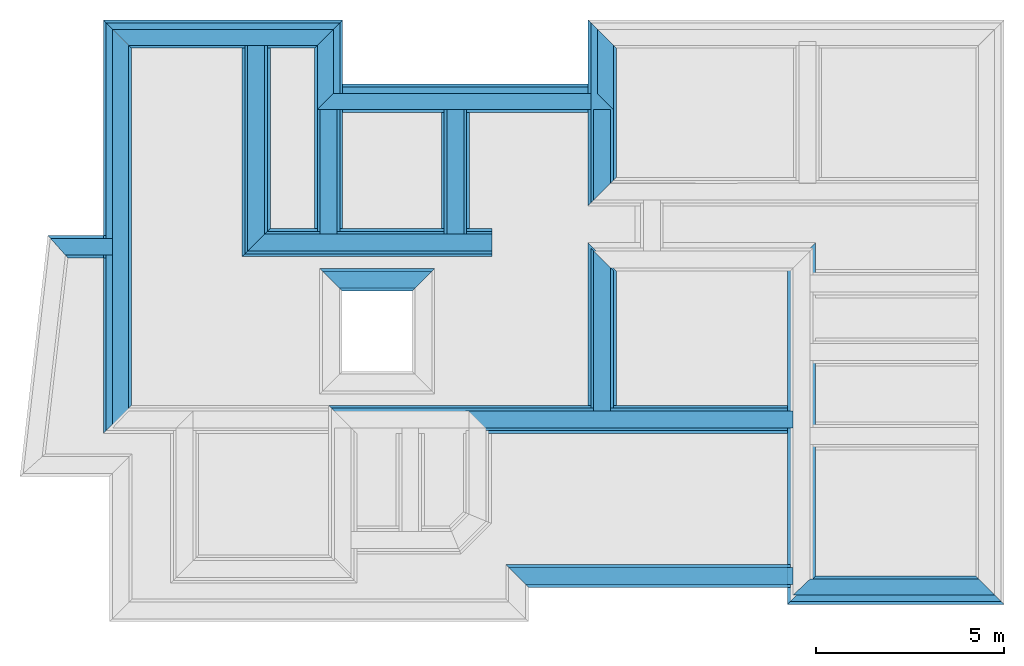
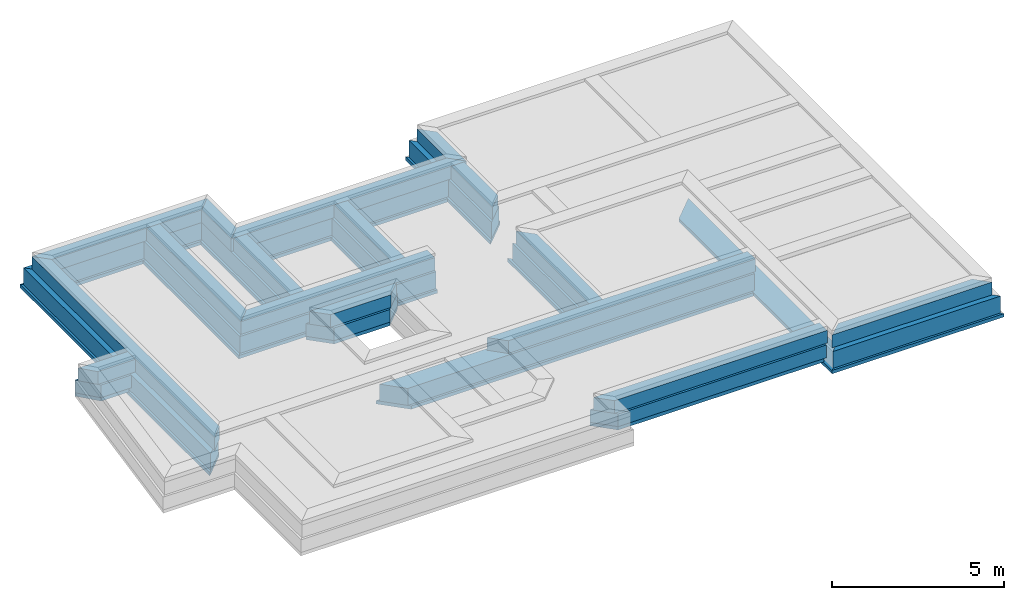
# One storey, part 3 of 6: 45 walls.
"""IFC4X3_ADD2 building model written with IfcOpenShell, lengths in metres."""

from ifc_helpers import new_model, entity, si_unit, converted_unit, frame, origin_with_axes, origin_2d_with_axis, place, context, subcontext, project, spatial, line, indexed_curve, outline, extrude, material, layer, layer_set, layer_usage, type_object, element, save


model = new_model("IFC4X3_ADD2")

# Units and contexts
model_context = context("Model", 3, precision=1e-05, world=origin_with_axes())
plan_context = context("Plan", 2, precision=1e-05, world=origin_2d_with_axis())
body_context = subcontext(model_context, "Body", "Model", "MODEL_VIEW")
ifc_project = project(units=[si_unit("VOLUMEUNIT", "CUBIC_METRE"), si_unit("LENGTHUNIT", "METRE"), converted_unit("PLANEANGLEUNIT", "degree", entity("IfcReal", 0.0174532925199433), si_unit("PLANEANGLEUNIT", "RADIAN"), dimensions=[0, 0, 0, 0, 0, 0, 0]), si_unit("AREAUNIT", "SQUARE_METRE")], contexts=[model_context, plan_context])

# Site, building, storey
site_placement = place(None, origin_with_axes())
site = spatial("IfcSite", under=ifc_project, at=site_placement)
building_placement = place(site_placement, origin_with_axes())
building = spatial("IfcBuilding", under=site, at=building_placement, Name="Building")
storey_placement = place(building_placement, frame((0.0, 0.0, -0.870000004768372), z_axis=(0.0, 0.0, 1.0), x_axis=(1.0, 0.0, 0.0)))
storey = spatial("IfcBuildingStorey", under=building, at=storey_placement, Name="Footing")

# Walls
ifc_material_1 = material(Name="Stone", Category="Structure")
ifc_layer_1 = layer(ifc_material_1, 0.449999988079071)
ifc_layer_set_1 = layer_set([ifc_layer_1])
ifc_layer_usage_1 = layer_usage(ifc_layer_set_1, "AXIS2", "POSITIVE", 0.0)
wall_type_1 = type_object("IfcWallType", Name="RRB Basement", PredefinedType="SHEAR", material=ifc_layer_set_1)
wall_1_placement = place(storey_placement, frame((11.1843014234303, 20.5243861418143, 0.719999998807908), z_axis=(0.0, 0.0, 1.0), x_axis=(3.13916473260163e-07, 0.999999999999951, 0.0)))
element("IfcWall", 1, at=wall_1_placement, inside=storey, type_object=wall_type_1, material=ifc_layer_usage_1, Name="Wall", context=body_context, shape_type="SweptSolid", body=[
    extrude(outline(indexed_curve([(0.449999988079093, 0.0), (0.450000131326058, 0.449999988079071), (3.76552144418195, 0.449999988079071), (3.76552141414186, 0.0)], segments=[line(1, 2, 3, 4, 1)])), origin_with_axes(), (0.0, 0.0, 1.0), 0.449999988079071),
])
ifc_layer_usage_2 = layer_usage(ifc_layer_set_1, "AXIS2", "POSITIVE", 0.0)
wall_2_placement = place(storey_placement, frame((15.0466774778525, 15.8160228729249, 0.719999998807908), z_axis=(0.0, 0.0, 1.0), x_axis=(0.999999999999822, -5.960464477538e-07, 0.0)))
element("IfcWall", 2, at=wall_2_placement, inside=storey, type_object=wall_type_1, material=ifc_layer_usage_2, Name="Wall", context=body_context, shape_type="SweptSolid", body=[
    extrude(outline(indexed_curve([(0.0, 0.0), (-0.450000103371296, 0.449999988079071), (8.2783390779459, 0.449999988079071), (8.27833917616148, 0.0)], segments=[line(1, 2, 3, 4, 1)])), origin_with_axes(), (0.0, 0.0, 1.0), 0.449999988079071),
])
ifc_layer_usage_3 = layer_usage(ifc_layer_set_1, "AXIS2", "POSITIVE", 0.0)
wall_3_placement = place(storey_placement, frame((14.5602179044483, 20.5243840074145, 0.719999998807908), z_axis=(0.0, 0.0, 1.0), x_axis=(3.13916473260163e-07, 0.999999999999951, 0.0)))
element("IfcWall", 3, at=wall_3_placement, inside=storey, type_object=wall_type_1, material=ifc_layer_usage_3, Name="Wall", context=body_context, shape_type="SweptSolid", body=[
    extrude(outline(indexed_curve([(0.449999988079094, 0.0), (0.450000131326058, 0.449999988079071), (3.76552229320457, 0.449999988079071), (3.76552226325902, 0.0)], segments=[line(1, 2, 3, 4, 1)])), origin_with_axes(), (0.0, 0.0, 1.0), 0.449999988079071),
])
ifc_layer_usage_4 = layer_usage(ifc_layer_set_1, "AXIS2", "POSITIVE", 0.0)
wall_4_placement = place(storey_placement, frame((9.25813584268061, 20.5243873596191, 0.719999998807908), z_axis=(0.0, 0.0, 1.0), x_axis=(3.13916473260163e-07, 0.999999999999951, 0.0)))
element("IfcWall", 4, at=wall_4_placement, inside=storey, type_object=wall_type_1, material=ifc_layer_usage_4, Name="Wall", context=body_context, shape_type="SweptSolid", body=[
    extrude(outline(indexed_curve([(0.449999988079093, 0.0), (1.43246964352757e-07, 0.449999988079071), (5.57351498957041, 0.449999988079071), (5.57351496081623, 0.0)], segments=[line(1, 2, 3, 4, 1)])), origin_with_axes(), (0.0, 0.0, 1.0), 0.449999988079071),
])
ifc_layer_usage_5 = layer_usage(ifc_layer_set_1, "AXIS2", "POSITIVE", 0.0)
wall_5_placement = place(storey_placement, frame((9.25813584427108, 20.5243873596191, 0.719999998807908), z_axis=(0.0, 0.0, 1.0), x_axis=(0.999999999999822, -5.960464477538e-07, 0.0)))
element("IfcWall", 5, at=wall_5_placement, inside=storey, type_object=wall_type_1, material=ifc_layer_usage_5, Name="Wall", context=body_context, shape_type="SweptSolid", body=[
    extrude(outline(indexed_curve([(-0.449999988079087, 0.0), (-1.22067763074548e-07, 0.449999988079071), (6.05208381845608, 0.449999988079071), (6.05208381845608, 0.0)], segments=[line(1, 2, 3, 4, 1)])), origin_with_axes(), (0.0, 0.0, 1.0), 0.449999988079071),
])
ifc_layer_usage_6 = layer_usage(ifc_layer_set_1, "AXIS2", "POSITIVE", 0.0)
wall_6_placement = place(storey_placement, frame((18.466682434082, 21.8778953552246, 0.719999998807908), z_axis=(0.0, 0.0, 1.0), x_axis=(3.13916473260163e-07, 0.999999999999951, 0.0)))
element("IfcWall", 6, at=wall_6_placement, inside=storey, type_object=wall_type_1, material=ifc_layer_usage_6, Name="Wall", context=body_context, shape_type="SweptSolid", body=[
    extrude(outline(indexed_curve([(0.44999998807909, 0.0), (1.2982553602409e-07, 0.449999988079071), (2.41201430465592, 0.449999988079071), (2.41201460685087, 0.0)], segments=[line(1, 2, 3, 4, 1)])), origin_with_axes(), (0.0, 0.0, 1.0), 0.449999988079071),
])
ifc_layer_usage_7 = layer_usage(ifc_layer_set_1, "AXIS2", "POSITIVE", 0.0)
wall_7_placement = place(storey_placement, frame((18.466680573821, 15.8160208088996, 0.719999998807908), z_axis=(0.0, 0.0, 1.0), x_axis=(3.13916473260163e-07, 0.999999999999951, 0.0)))
element("IfcWall", 7, at=wall_7_placement, inside=storey, type_object=wall_type_1, material=ifc_layer_usage_7, Name="Wall", context=body_context, shape_type="SweptSolid", body=[
    extrude(outline(indexed_curve([(0.44999998807909, 0.0), (0.450000118398703, 0.449999988079071), (4.70687373541192, 0.449999988079071), (4.256873653544, 0.0)], segments=[line(1, 2, 3, 4, 1)])), origin_with_axes(), (0.0, 0.0, 1.0), 0.449999988079071),
])
ifc_layer_usage_8 = layer_usage(ifc_layer_set_1, "AXIS2", "POSITIVE", 0.0)
wall_8_placement = place(storey_placement, frame((16.2040448841746, 11.6493488347191, 0.719999998807908), z_axis=(0.0, 0.0, 1.0), x_axis=(0.999999999999822, -5.960464477538e-07, 0.0)))
element("IfcWall", 8, at=wall_8_placement, inside=storey, type_object=wall_type_1, material=ifc_layer_usage_8, Name="Wall", context=body_context, shape_type="SweptSolid", body=[
    extrude(outline(indexed_curve([(0.0, 0.0), (-0.449999989155844, 0.449999988079071), (7.12097009124434, 0.449999988079071), (7.12097018937736, 0.0)], segments=[line(1, 2, 3, 4, 1)])), origin_with_axes(), (0.0, 0.0, 1.0), 0.449999988079071),
])
ifc_layer_usage_9 = layer_usage(ifc_layer_set_1, "AXIS2", "POSITIVE", 0.0)
wall_9_placement = place(storey_placement, frame((5.6390405123403, 20.8634834375414, 0.719999998807908), z_axis=(0.0, 0.0, 1.0), x_axis=(-0.999999999999803, 6.27832946520233e-07, 0.0)))
element("IfcWall", 9, at=wall_9_placement, inside=storey, type_object=wall_type_1, material=ifc_layer_usage_9, Name="Wall", context=body_context, shape_type="SweptSolid", body=[
    extrude(outline(indexed_curve([(0.425000000745078, 0.0), (0.424999862371063, 0.449999988079071), (1.68367306365502, 0.449999988079071), (2.08469309225921, 0.0)], segments=[line(1, 2, 3, 4, 1)])), origin_with_axes(), (0.0, 0.0, 1.0), 0.449999988079071),
])
ifc_layer_usage_10 = layer_usage(ifc_layer_set_1, "AXIS2", "POSITIVE", 0.0)
wall_10_placement = place(storey_placement, frame((13.7089599315482, 19.9843861870825, 0.719999983906746), z_axis=(0.0, 0.0, 1.0), x_axis=(-0.999999999999803, 6.27832946520233e-07, 0.0)))
element("IfcWall", 10, at=wall_10_placement, inside=storey, type_object=wall_type_1, material=ifc_layer_usage_10, Name="Wall", context=body_context, shape_type="SweptSolid", body=[
    extrude(outline(indexed_curve([(0.0, 0.0), (0.450000016741684, 0.449999988079071), (2.46327593529409, 0.449999988079071), (2.91327589750235, 0.0)], segments=[line(1, 2, 3, 4, 1)])), origin_with_axes(), (0.0, 0.0, 1.0), 0.449999988079071),
])
ifc_material_2 = material(Name="Plaster", Category="Finishes")
ifc_layer_2 = layer(ifc_material_2, 0.00999999977648258)
ifc_layer_3 = layer(ifc_material_1, 0.405000001192093)
ifc_layer_4 = layer(ifc_material_2, 0.00999999977648258)
ifc_layer_set_2 = layer_set([ifc_layer_2, ifc_layer_3, ifc_layer_4])
ifc_layer_usage_11 = layer_usage(ifc_layer_set_2, "AXIS2", "POSITIVE", 0.0)
wall_type_2 = type_object("IfcWallType", Name="RRB Basement Flush 425", PredefinedType="SHEAR", material=ifc_layer_set_2)
wall_11_placement = place(storey_placement, frame((11.0843045825103, 26.4228992462159, 0.719999998807908), z_axis=(0.0, 0.0, 1.0), x_axis=(-0.999999999999924, 3.89414367418765e-07, 0.0)))
element("IfcWall", 11, at=wall_11_placement, inside=storey, type_object=wall_type_2, material=ifc_layer_usage_11, Name="Wall", context=body_context, shape_type="SweptSolid", body=[
    extrude(outline(indexed_curve([(0.0, 0.0), (0.424999984673434, 0.425000000745058), (5.44526225995521, 0.425000000745058), (5.87026229003865, 0.0)], segments=[line(1, 2, 3, 4, 1)])), origin_with_axes(), (0.0, 0.0, 1.0), 0.449999988079071),
])
ifc_layer_usage_12 = layer_usage(ifc_layer_set_2, "AXIS2", "POSITIVE", 0.0)
wall_12_placement = place(storey_placement, frame((18.5416841319606, 24.7149047559503, 0.719999998807908), z_axis=(0.0, 0.0, 1.0), x_axis=(-0.999999999999924, 3.89414367418765e-07, 0.0)))
element("IfcWall", 12, at=wall_12_placement, inside=storey, type_object=wall_type_2, material=ifc_layer_usage_12, Name="Wall", context=body_context, shape_type="SweptSolid", body=[
    extrude(outline(indexed_curve([(0.425000000745095, 0.0), (-5.01506110114182e-07, 0.425000000745058), (7.88238015246545, 0.425000000745058), (7.45738016349185, 0.0)], segments=[line(1, 2, 3, 4, 1)])), origin_with_axes(), (0.0, 0.0, 1.0), 0.449999988079071),
])
ifc_layer_usage_13 = layer_usage(ifc_layer_set_2, "AXIS2", "POSITIVE", 0.0)
wall_13_placement = place(storey_placement, frame((5.63903903961169, 16.2660213158936, 0.719999998807908), z_axis=(0.0, 0.0, 1.0), x_axis=(3.13916473260163e-07, 0.999999999999951, 0.0)))
element("IfcWall", 13, at=wall_13_placement, inside=storey, type_object=wall_type_2, material=ifc_layer_usage_13, Name="Wall", context=body_context, shape_type="SweptSolid", body=[
    extrude(outline(indexed_curve([(0.0, 0.0), (-0.450000223773091, 0.425000000745058), (10.156880012591, 0.425000000745058), (9.73187998484762, 0.0)], segments=[line(1, 2, 3, 4, 1)])), origin_with_axes(), (0.0, 0.0, 1.0), 0.449999988079071),
])
ifc_layer_usage_14 = layer_usage(ifc_layer_set_2, "AXIS2", "POSITIVE", 0.0)
wall_14_placement = place(storey_placement, frame((23.7750149621858, 11.3693475723266, 0.719999998807908), z_axis=(0.0, 0.0, 1.0), x_axis=(0.999999999999822, -5.960464477538e-07, 0.0)))
element("IfcWall", 14, at=wall_14_placement, inside=storey, type_object=wall_type_2, material=ifc_layer_usage_14, Name="Wall", context=body_context, shape_type="SweptSolid", body=[
    extrude(outline(indexed_curve([(-0.449999988079081, 0.0), (-9.26811892745667e-08, 0.425000000745058), (4.48665335278053, 0.425000000745058), (4.91165347159026, 0.0)], segments=[line(1, 2, 3, 4, 1)])), origin_with_axes(), (0.0, 0.0, 1.0), 0.449999988079071),
])
ifc_layer_usage_15 = layer_usage(ifc_layer_set_2, "AXIS2", "POSITIVE", 0.0)
wall_15_placement = place(storey_placement, frame((11.0843039684693, 24.7149075947677, 0.719999998807908), z_axis=(0.0, 0.0, 1.0), x_axis=(3.13916473260163e-07, 0.999999999999951, 0.0)))
element("IfcWall", 15, at=wall_15_placement, inside=storey, type_object=wall_type_2, material=ifc_layer_usage_15, Name="Wall", context=body_context, shape_type="SweptSolid", body=[
    extrude(outline(indexed_curve([(0.0, 0.0), (-0.424999972373865, 0.425000000745058), (1.2829916777015, 0.425000000745058), (1.70799165144828, 0.0)], segments=[line(1, 2, 3, 4, 1)])), origin_with_axes(), (0.0, 0.0, 1.0), 0.449999988079071),
])
ifc_layer_usage_16 = layer_usage(ifc_layer_set_2, "AXIS2", "POSITIVE", 0.0)
wall_16_placement = place(storey_placement, frame((18.5416841319606, 24.7149047566126, 0.719999998807908), z_axis=(0.0, 0.0, 1.0), x_axis=(3.13916473260163e-07, 0.999999999999951, 0.0)))
element("IfcWall", 16, at=wall_16_placement, inside=storey, type_object=wall_type_2, material=ifc_layer_usage_16, Name="Wall", context=body_context, shape_type="SweptSolid", body=[
    extrude(outline(indexed_curve([(-0.425000000745059, 0.0), (2.83334474771024e-08, 0.425000000745058), (1.70799653596367, 0.425000000745058), (1.28299650586313, 0.0)], segments=[line(1, 2, 3, 4, 1)])), origin_with_axes(), (0.0, 0.0, 1.0), 0.449999988079071),
])
ifc_material_3 = material(Name="Wall")
ifc_layer_5 = layer(ifc_material_3, 0.600000023841858, Name="concrete")
ifc_layer_set_3 = layer_set([ifc_layer_5], Name="concrete")
ifc_layer_usage_17 = layer_usage(ifc_layer_set_3, "AXIS2", "POSITIVE", 0.0)
wall_type_3 = type_object("IfcWallType", Name="RRB Foundation", PredefinedType="SHEAR", material=ifc_layer_set_3)
wall_17_placement = place(storey_placement, frame((18.5416813132168, 21.802896544815, 0.120000004768372), z_axis=(0.0, 0.0, 1.0), x_axis=(3.13916473260163e-07, 0.999999999999951, 0.0)))
element("IfcWall", 17, at=wall_17_placement, inside=storey, type_object=wall_type_3, material=ifc_layer_usage_17, Name="Wall", context=body_context, shape_type="SweptSolid", body=[
    extrude(outline(indexed_curve([(0.600000023841883, 0.0), (1.7306831381862e-07, 0.600000023841858), (4.79500596321352, 0.600000023841858), (4.19500589786325, 0.0)], segments=[line(1, 2, 3, 4, 1)])), origin_with_axes(), (0.0, 0.0, 1.0), 0.600000023841858),
])
ifc_layer_usage_18 = layer_usage(ifc_layer_set_3, "AXIS2", "POSITIVE", 0.0)
wall_18_placement = place(storey_placement, frame((9.33313562840178, 20.4493865966797, 0.120000004768372), z_axis=(0.0, 0.0, 1.0), x_axis=(3.13916473260163e-07, 0.999999999999951, 0.0)))
element("IfcWall", 18, at=wall_18_placement, inside=storey, type_object=wall_type_3, material=ifc_layer_usage_18, Name="Wall", context=body_context, shape_type="SweptSolid", body=[
    extrude(outline(indexed_curve([(0.600000023841888, 0.0), (1.91268479846074e-07, 0.600000023841858), (5.54851456538258, 0.600000023841858), (5.54851452704368, 0.0)], segments=[line(1, 2, 3, 4, 1)])), origin_with_axes(), (0.0, 0.0, 1.0), 0.600000023841858),
])
ifc_layer_usage_19 = layer_usage(ifc_layer_set_3, "AXIS2", "POSITIVE", 0.0)
wall_19_placement = place(storey_placement, frame((18.5416823246089, 24.8899059587721, 0.120000004768372), z_axis=(0.0, 0.0, 1.0), x_axis=(-0.999999999999924, 3.89414367418765e-07, 0.0)))
element("IfcWall", 19, at=wall_19_placement, inside=storey, type_object=wall_type_3, material=ifc_layer_usage_19, Name="Wall", context=body_context, shape_type="SweptSolid", body=[
    extrude(outline(indexed_curve([(0.600000023841859, 0.0), (0.599999986700795, 0.600000023841858), (7.2823786814523, 0.600000023841858), (7.28237872038916, 0.0)], segments=[line(1, 2, 3, 4, 1)])), origin_with_axes(), (0.0, 0.0, 1.0), 0.600000023841858),
])
ifc_layer_usage_20 = layer_usage(ifc_layer_set_3, "AXIS2", "POSITIVE", 0.0)
wall_20_placement = place(storey_placement, frame((18.5416794058681, 15.7410208639421, 0.120000004768372), z_axis=(0.0, 0.0, 1.0), x_axis=(3.13916473260163e-07, 0.999999999999951, 0.0)))
element("IfcWall", 20, at=wall_20_placement, inside=storey, type_object=wall_type_3, material=ifc_layer_usage_20, Name="Wall", context=body_context, shape_type="SweptSolid", body=[
    extrude(outline(indexed_curve([(0.600000023841883, 0.0), (0.600000196322957, 0.600000023841858), (4.85687366928037, 0.600000023841858), (4.25687346879169, 0.0)], segments=[line(1, 2, 3, 4, 1)])), origin_with_axes(), (0.0, 0.0, 1.0), 0.600000023841858),
])
ifc_layer_usage_21 = layer_usage(ifc_layer_set_3, "AXIS2", "POSITIVE", 0.0)
wall_21_placement = place(storey_placement, frame((11.2593041573632, 26.597900419831, 0.120000004768372), z_axis=(0.0, 0.0, 1.0), x_axis=(-0.999999999999924, 3.89414367418765e-07, 0.0)))
element("IfcWall", 21, at=wall_21_placement, inside=storey, type_object=wall_type_3, material=ifc_layer_usage_21, Name="Wall", context=body_context, shape_type="SweptSolid", body=[
    extrude(outline(indexed_curve([(0.0, 0.0), (0.599999984828332, 0.600000023841858), (5.62026181561733, 0.600000023841858), (6.22026188091619, 0.0)], segments=[line(1, 2, 3, 4, 1)])), origin_with_axes(), (0.0, 0.0, 1.0), 0.600000023841858),
])
ifc_layer_usage_22 = layer_usage(ifc_layer_set_3, "AXIS2", "POSITIVE", 0.0)
wall_22_placement = place(storey_placement, frame((11.2593021628258, 20.4493853779994, 0.120000004768372), z_axis=(0.0, 0.0, 1.0), x_axis=(3.13916473260163e-07, 0.999999999999951, 0.0)))
element("IfcWall", 22, at=wall_22_placement, inside=storey, type_object=wall_type_3, material=ifc_layer_usage_22, Name="Wall", context=body_context, shape_type="SweptSolid", body=[
    extrude(outline(indexed_curve([(0.600000023841888, 0.0), (0.600000215110368, 0.600000023841858), (5.54851505632895, 0.600000023841858), (6.1485150418319, 0.0)], segments=[line(1, 2, 3, 4, 1)])), origin_with_axes(), (0.0, 0.0, 1.0), 0.600000023841858),
])
ifc_layer_usage_23 = layer_usage(ifc_layer_set_3, "AXIS2", "POSITIVE", 0.0)
wall_23_placement = place(storey_placement, frame((11.6379987314599, 15.7410250157116, 0.120000004768372), z_axis=(0.0, 0.0, 1.0), x_axis=(0.999999999999822, -5.960464477538e-07, 0.0)))
element("IfcWall", 23, at=wall_23_placement, inside=storey, type_object=wall_type_3, material=ifc_layer_usage_23, Name="Wall", context=body_context, shape_type="SweptSolid", body=[
    extrude(outline(indexed_curve([(0.0, 0.0), (-0.600000181284445, 0.600000023841858), (11.6120162987777, 0.600000023841858), (11.6120164636125, 0.0)], segments=[line(1, 2, 3, 4, 1)])), origin_with_axes(), (0.0, 0.0, 1.0), 0.600000023841858),
])
ifc_layer_usage_24 = layer_usage(ifc_layer_set_3, "AXIS2", "POSITIVE", 0.0)
wall_24_placement = place(storey_placement, frame((9.33313562918742, 20.4493865966797, 0.120000004768372), z_axis=(0.0, 0.0, 1.0), x_axis=(0.999999999999822, -5.960464477538e-07, 0.0)))
element("IfcWall", 24, at=wall_24_placement, inside=storey, type_object=wall_type_3, material=ifc_layer_usage_24, Name="Wall", context=body_context, shape_type="SweptSolid", body=[
    extrude(outline(indexed_curve([(-0.60000002384188, 0.0), (-1.62916114084486e-07, 0.600000023841858), (5.97708403273492, 0.600000023841858), (5.97708403273492, 0.0)], segments=[line(1, 2, 3, 4, 1)])), origin_with_axes(), (0.0, 0.0, 1.0), 0.600000023841858),
])
ifc_layer_usage_25 = layer_usage(ifc_layer_set_3, "AXIS2", "POSITIVE", 0.0)
wall_25_placement = place(storey_placement, frame((5.63903901606797, 16.3410209768514, 0.120000004768372), z_axis=(0.0, 0.0, 1.0), x_axis=(3.13916473260163e-07, 0.999999999999951, 0.0)))
element("IfcWall", 25, at=wall_25_placement, inside=storey, type_object=wall_type_3, material=ifc_layer_usage_25, Name="Wall", context=body_context, shape_type="SweptSolid", body=[
    extrude(outline(indexed_curve([(0.0, 0.0), (-0.5999999850636, 0.600000023841858), (10.2568816047363, 0.600000023841858), (9.6568815425555, 0.0)], segments=[line(1, 2, 3, 4, 1)])), origin_with_axes(), (0.0, 0.0, 1.0), 0.600000023841858),
])
ifc_layer_usage_26 = layer_usage(ifc_layer_set_3, "AXIS2", "POSITIVE", 0.0)
wall_26_placement = place(storey_placement, frame((23.8500137570046, 11.1943474262957, 0.120000004768372), z_axis=(0.0, 0.0, 1.0), x_axis=(0.999999999999822, -5.960464477538e-07, 0.0)))
element("IfcWall", 26, at=wall_26_placement, inside=storey, type_object=wall_type_3, material=ifc_layer_usage_26, Name="Wall", context=body_context, shape_type="SweptSolid", body=[
    extrude(outline(indexed_curve([(-0.600000023841881, 0.0), (-1.64834769827047e-07, 0.600000023841858), (4.41165561690321, 0.600000023841858), (5.01165580749597, 0.0)], segments=[line(1, 2, 3, 4, 1)])), origin_with_axes(), (0.0, 0.0, 1.0), 0.600000023841858),
])
ifc_layer_usage_27 = layer_usage(ifc_layer_set_3, "AXIS2", "POSITIVE", 0.0)
wall_27_placement = place(storey_placement, frame((14.6352186203005, 20.3743844314932, 0.120000004768372), z_axis=(0.0, 0.0, 1.0), x_axis=(3.13916473260163e-07, 0.999999999999951, 0.0)))
element("IfcWall", 27, at=wall_27_placement, inside=storey, type_object=wall_type_3, material=ifc_layer_usage_27, Name="Wall", context=body_context, shape_type="SweptSolid", body=[
    extrude(outline(indexed_curve([(0.600000023841888, 0.0), (0.600000215389809, 0.600000023841858), (3.91552302920591, 0.600000023841858), (3.9155229893344, 0.0)], segments=[line(1, 2, 3, 4, 1)])), origin_with_axes(), (0.0, 0.0, 1.0), 0.600000023841858),
])
ifc_layer_usage_28 = layer_usage(ifc_layer_set_3, "AXIS2", "POSITIVE", 0.0)
wall_28_placement = place(storey_placement, frame((23.8500140713483, 12.1743445783882, 0.269999980926514), z_axis=(0.0, 0.0, 1.0), x_axis=(-0.999999999999924, 3.89414367418765e-07, 0.0)))
element("IfcWall", 28, at=wall_28_placement, inside=storey, type_object=wall_type_3, material=ifc_layer_usage_28, Name="Wall", context=body_context, shape_type="SweptSolid", body=[
    extrude(outline(indexed_curve([(0.600000023841859, 0.0), (0.599999982986343, 0.600000023841858), (7.57096725031161, 0.600000023841858), (8.17096530502794, 0.0)], segments=[line(1, 2, 3, 4, 1)])), origin_with_axes(), (0.0, 0.0, 1.0), 0.449999988079071),
])
ifc_layer_usage_29 = layer_usage(ifc_layer_set_3, "AXIS2", "POSITIVE", 0.0)
wall_29_placement = place(storey_placement, frame((5.63904048850912, 20.9384838708685, 0.269999980926514), z_axis=(0.0, 0.0, 1.0), x_axis=(-0.999999999999803, 6.27832946520233e-07, 0.0)))
element("IfcWall", 29, at=wall_29_placement, inside=storey, type_object=wall_type_3, material=ifc_layer_usage_29, Name="Wall", context=body_context, shape_type="SweptSolid", body=[
    extrude(outline(indexed_curve([(0.600000023841886, 0.0), (0.599999839305639, 0.600000023841858), (1.61683742049565, 0.600000023841858), (2.15153083745776, 0.0)], segments=[line(1, 2, 3, 4, 1)])), origin_with_axes(), (0.0, 0.0, 1.0), 0.449999988079071),
])
ifc_layer_usage_30 = layer_usage(ifc_layer_set_3, "AXIS2", "POSITIVE", 0.0)
wall_30_placement = place(storey_placement, frame((10.7206868734936, 19.4593892768367, 0.269999980926514), z_axis=(0.0, 0.0, 1.0), x_axis=(0.999999999999886, -4.76837158203071e-07, 0.0)))
element("IfcWall", 30, at=wall_30_placement, inside=storey, type_object=wall_type_3, material=ifc_layer_usage_30, Name="Wall", context=body_context, shape_type="SweptSolid", body=[
    extrude(outline(indexed_curve([(0.600000023841886, 0.0), (6.56667492426315e-07, 0.600000023841858), (3.06327801910507, 0.600000023841858), (2.46327590943912, 0.0)], segments=[line(1, 2, 3, 4, 1)])), origin_with_axes(), (0.0, 0.0, 1.0), 0.449999988079071),
])
ifc_layer_6 = layer(ifc_material_3, 0.75)
ifc_layer_set_4 = layer_set([ifc_layer_6])
ifc_layer_usage_31 = layer_usage(ifc_layer_set_4, "AXIS2", "POSITIVE", 0.0)
wall_type_4 = type_object("IfcWallType", Name="PCC 120mm", PredefinedType="SHEAR", material=ifc_layer_set_4)
wall_31_placement = place(storey_placement, frame((11.3343043265543, 26.6729009988723, 0.0), z_axis=(0.0, 0.0, 1.0), x_axis=(-0.999999999999924, 3.89414367418765e-07, 0.0)))
element("IfcWall", 31, at=wall_31_placement, inside=storey, type_object=wall_type_4, material=ifc_layer_usage_31, Name="Wall", context=body_context, shape_type="SweptSolid", body=[
    extrude(outline(indexed_curve([(0.0, 0.0), (0.749999951139541, 0.75), (5.62026220810672, 0.75), (6.37026225996308, 0.0)], segments=[line(1, 2, 3, 4, 1)])), origin_with_axes(), (0.0, 0.0, 1.0), 0.119999997317791),
])
ifc_layer_usage_32 = layer_usage(ifc_layer_set_4, "AXIS2", "POSITIVE", 0.0)
wall_32_placement = place(storey_placement, frame((18.6166831257379, 24.9649062643639, 0.0), z_axis=(0.0, 0.0, 1.0), x_axis=(-0.999999999999924, 3.89414367418765e-07, 0.0)))
element("IfcWall", 32, at=wall_32_placement, inside=storey, type_object=wall_type_4, material=ifc_layer_usage_32, Name="Wall", context=body_context, shape_type="SweptSolid", body=[
    extrude(outline(indexed_curve([(0.750000000000001, 0.0), (0.749999954027897, 0.75), (7.28237930416929, 0.75), (7.28237935302975, 0.0)], segments=[line(1, 2, 3, 4, 1)])), origin_with_axes(), (0.0, 0.0, 1.0), 0.119999997317791),
])
ifc_layer_usage_33 = layer_usage(ifc_layer_set_4, "AXIS2", "POSITIVE", 0.0)
wall_33_placement = place(storey_placement, frame((5.71403878159405, 16.416021684612, 0.0), z_axis=(0.0, 0.0, 1.0), x_axis=(3.13916473260163e-07, 0.999999999999951, 0.0)))
element("IfcWall", 33, at=wall_33_placement, inside=storey, type_object=wall_type_4, material=ifc_layer_usage_33, Name="Wall", context=body_context, shape_type="SweptSolid", body=[
    extrude(outline(indexed_curve([(0.0, 0.0), (-0.74999995152718, 0.75), (10.2568814856018, 0.75), (9.50688143767821, 0.0)], segments=[line(1, 2, 3, 4, 1)])), origin_with_axes(), (0.0, 0.0, 1.0), 0.119999997317791),
])
ifc_layer_usage_34 = layer_usage(ifc_layer_set_4, "AXIS2", "POSITIVE", 0.0)
wall_34_placement = place(storey_placement, frame((11.3343022841534, 20.3743867690882, 0.0), z_axis=(0.0, 0.0, 1.0), x_axis=(3.13916473260163e-07, 0.999999999999951, 0.0)))
element("IfcWall", 34, at=wall_34_placement, inside=storey, type_object=wall_type_4, material=ifc_layer_usage_34, Name="Wall", context=body_context, shape_type="SweptSolid", body=[
    extrude(outline(indexed_curve([(0.750000000000038, 0.0), (0.750000239434929, 0.75), (5.54851427770804, 0.75), (6.29851422978442, 0.0)], segments=[line(1, 2, 3, 4, 1)])), origin_with_axes(), (0.0, 0.0, 1.0), 0.119999997317791),
])
ifc_layer_usage_35 = layer_usage(ifc_layer_set_4, "AXIS2", "POSITIVE", 0.0)
wall_35_placement = place(storey_placement, frame((9.40813504085922, 20.3743879886661, 0.0), z_axis=(0.0, 0.0, 1.0), x_axis=(3.13916473260163e-07, 0.999999999999951, 0.0)))
element("IfcWall", 35, at=wall_35_placement, inside=storey, type_object=wall_type_4, material=ifc_layer_usage_35, Name="Wall", context=body_context, shape_type="SweptSolid", body=[
    extrude(outline(indexed_curve([(0.750000000000038, 0.0), (2.39434890939613e-07, 0.75), (5.54851378586441, 0.75), (5.54851373794079, 0.0)], segments=[line(1, 2, 3, 4, 1)])), origin_with_axes(), (0.0, 0.0, 1.0), 0.119999997317791),
])
ifc_layer_usage_36 = layer_usage(ifc_layer_set_4, "AXIS2", "POSITIVE", 0.0)
wall_36_placement = place(storey_placement, frame((9.40813504085922, 20.3743879886661, 0.0), z_axis=(0.0, 0.0, 1.0), x_axis=(0.999999999999822, -5.960464477538e-07, 0.0)))
element("IfcWall", 36, at=wall_36_placement, inside=storey, type_object=wall_type_4, material=ifc_layer_usage_36, Name="Wall", context=body_context, shape_type="SweptSolid", body=[
    extrude(outline(indexed_curve([(-0.750000000000028, 0.0), (-2.03834519745982e-07, 0.75), (5.90208424701316, 0.75), (5.90208424701316, 0.0)], segments=[line(1, 2, 3, 4, 1)])), origin_with_axes(), (0.0, 0.0, 1.0), 0.119999997317791),
])
ifc_layer_usage_37 = layer_usage(ifc_layer_set_4, "AXIS2", "POSITIVE", 0.0)
wall_37_placement = place(storey_placement, frame((14.7102183011036, 20.3743844742758, 0.0), z_axis=(0.0, 0.0, 1.0), x_axis=(3.13916473260163e-07, 0.999999999999951, 0.0)))
element("IfcWall", 37, at=wall_37_placement, inside=storey, type_object=wall_type_4, material=ifc_layer_usage_37, Name="Wall", context=body_context, shape_type="SweptSolid", body=[
    extrude(outline(indexed_curve([(0.750000000000038, 0.0), (0.750000241542329, 0.75), (3.84052332842058, 0.75), (3.84052328013086, 0.0)], segments=[line(1, 2, 3, 4, 1)])), origin_with_axes(), (0.0, 0.0, 1.0), 0.119999997317791),
])
ifc_layer_usage_38 = layer_usage(ifc_layer_set_4, "AXIS2", "POSITIVE", 0.0)
wall_38_placement = place(storey_placement, frame((18.6166820631397, 21.7278964521527, 0.0), z_axis=(0.0, 0.0, 1.0), x_axis=(3.13916473260163e-07, 0.999999999999951, 0.0)))
element("IfcWall", 38, at=wall_38_placement, inside=storey, type_object=wall_type_4, material=ifc_layer_usage_38, Name="Wall", context=body_context, shape_type="SweptSolid", body=[
    extrude(outline(indexed_curve([(0.750000000000031, 0.0), (2.16893068331891e-07, 0.75), (4.94500712925562, 0.75), (4.1950070773701, 0.0)], segments=[line(1, 2, 3, 4, 1)])), origin_with_axes(), (0.0, 0.0, 1.0), 0.119999997317791),
])
ifc_layer_usage_39 = layer_usage(ifc_layer_set_4, "AXIS2", "POSITIVE", 0.0)
wall_39_placement = place(storey_placement, frame((18.6166796713225, 15.6660205047099, 0.0), z_axis=(0.0, 0.0, 1.0), x_axis=(3.13916473260163e-07, 0.999999999999951, 0.0)))
element("IfcWall", 39, at=wall_39_placement, inside=storey, type_object=wall_type_4, material=ifc_layer_usage_39, Name="Wall", context=body_context, shape_type="SweptSolid", body=[
    extrude(outline(indexed_curve([(0.750000000000031, 0.0), (0.750000216300797, 0.75), (5.08187320895466, 0.75), (4.33187298335619, 0.0)], segments=[line(1, 2, 3, 4, 1)])), origin_with_axes(), (0.0, 0.0, 1.0), 0.119999997317791),
])
ifc_layer_usage_40 = layer_usage(ifc_layer_set_4, "AXIS2", "POSITIVE", 0.0)
wall_40_placement = place(storey_placement, frame((23.9250144574532, 11.1193472715932, 0.0), z_axis=(0.0, 0.0, 1.0), x_axis=(3.13916473260163e-07, 0.999999999999951, 0.0)))
element("IfcWall", 40, at=wall_40_placement, inside=storey, type_object=wall_type_4, material=ifc_layer_usage_40, Name="Wall", context=body_context, shape_type="SweptSolid", body=[
    extrude(outline(indexed_curve([(0.750000000000039, 0.0), (2.44380802087435e-07, 0.75), (8.87854320807323, 0.75), (9.62854298726477, 0.0)], segments=[line(1, 2, 3, 4, 1)])), origin_with_axes(), (0.0, 0.0, 1.0), 0.119999997317791),
])
ifc_layer_usage_41 = layer_usage(ifc_layer_set_4, "AXIS2", "POSITIVE", 0.0)
wall_41_placement = place(storey_placement, frame((11.7129981960658, 15.6660246629181, 0.0), z_axis=(0.0, 0.0, 1.0), x_axis=(0.999999999999822, -5.960464477538e-07, 0.0)))
element("IfcWall", 41, at=wall_41_placement, inside=storey, type_object=wall_type_4, material=ifc_layer_usage_41, Name="Wall", context=body_context, shape_type="SweptSolid", body=[
    extrude(outline(indexed_curve([(0.0, 0.0), (-0.750000196459704, 0.75), (11.4620175211609, 0.75), (11.4620177265147, 0.0)], segments=[line(1, 2, 3, 4, 1)])), origin_with_axes(), (0.0, 0.0, 1.0), 0.119999997317791),
])
ifc_layer_usage_42 = layer_usage(ifc_layer_set_4, "AXIS2", "POSITIVE", 0.0)
wall_42_placement = place(storey_placement, frame((23.9250144574532, 11.1193472715932, 0.0), z_axis=(0.0, 0.0, 1.0), x_axis=(0.999999999999822, -5.960464477538e-07, 0.0)))
element("IfcWall", 42, at=wall_42_placement, inside=storey, type_object=wall_type_4, material=ifc_layer_usage_42, Name="Wall", context=body_context, shape_type="SweptSolid", body=[
    extrude(outline(indexed_curve([(-0.750000000000028, 0.0), (-2.06090370372681e-07, 0.75), (4.2616561413704, 0.75), (5.01165634982424, 0.0)], segments=[line(1, 2, 3, 4, 1)])), origin_with_axes(), (0.0, 0.0, 1.0), 0.119999997317791),
])
ifc_layer_7 = layer(ifc_material_3, 0.600000023841858, Name="concrete")
ifc_layer_set_5 = layer_set([ifc_layer_7], Name="concrete")
ifc_layer_usage_43 = layer_usage(ifc_layer_set_5, "AXIS2", "POSITIVE", 0.0)
wall_type_5 = type_object("IfcWallType", Name="60CM PCC", PredefinedType="SHEAR", material=ifc_layer_set_5)
wall_43_placement = place(storey_placement, frame((23.9250147963809, 12.1743444907698, 0.149999976158143), z_axis=(0.0, 0.0, 1.0), x_axis=(-0.999999999999924, 3.89414367418765e-07, 0.0)))
element("IfcWall", 43, at=wall_43_placement, inside=storey, type_object=wall_type_5, material=ifc_layer_usage_43, Name="Wall", context=body_context, shape_type="SweptSolid", body=[
    extrude(outline(indexed_curve([(0.750000000000002, 0.0), (0.749999959106952, 0.600000023841858), (7.64596970538998, 0.600000023841858), (8.24596967911119, 0.0)], segments=[line(1, 2, 3, 4, 1)])), origin_with_axes(), (0.0, 0.0, 1.0), 0.119999997317791),
])
ifc_layer_usage_44 = layer_usage(ifc_layer_set_5, "AXIS2", "POSITIVE", 0.0)
wall_44_placement = place(storey_placement, frame((5.71404023001452, 20.9384838237812, 0.149999976158143), z_axis=(0.0, 0.0, 1.0), x_axis=(-0.999999999999803, 6.27832946520233e-07, 0.0)))
element("IfcWall", 44, at=wall_44_placement, inside=storey, type_object=wall_type_5, material=ifc_layer_usage_44, Name="Wall", context=body_context, shape_type="SweptSolid", body=[
    extrude(outline(indexed_curve([(0.750000000000036, 0.0), (0.749999815463788, 0.600000023841858), (1.69183711281799, 0.600000023841858), (2.22653052981391, 0.0)], segments=[line(1, 2, 3, 4, 1)])), origin_with_axes(), (0.0, 0.0, 1.0), 0.119999997317791),
])
ifc_layer_usage_45 = layer_usage(ifc_layer_set_5, "AXIS2", "POSITIVE", 0.0)
wall_45_placement = place(storey_placement, frame((10.7206830498575, 19.4593855981233, 0.149999976158143), z_axis=(0.0, 0.0, 1.0), x_axis=(0.999999999999822, -5.960464477538e-07, 0.0)))
element("IfcWall", 45, at=wall_45_placement, inside=storey, type_object=wall_type_5, material=ifc_layer_usage_45, Name="Wall", context=body_context, shape_type="SweptSolid", body=[
    extrude(outline(indexed_curve([(0.600000023841857, 0.0), (-7.15048348612532e-09, 0.600000023841858), (3.06327585045119, 0.600000023841858), (2.46327590942337, 0.0)], segments=[line(1, 2, 3, 4, 1)])), origin_with_axes(), (0.0, 0.0, 1.0), 0.119999997317791),
])

save(model, "model.ifc")
